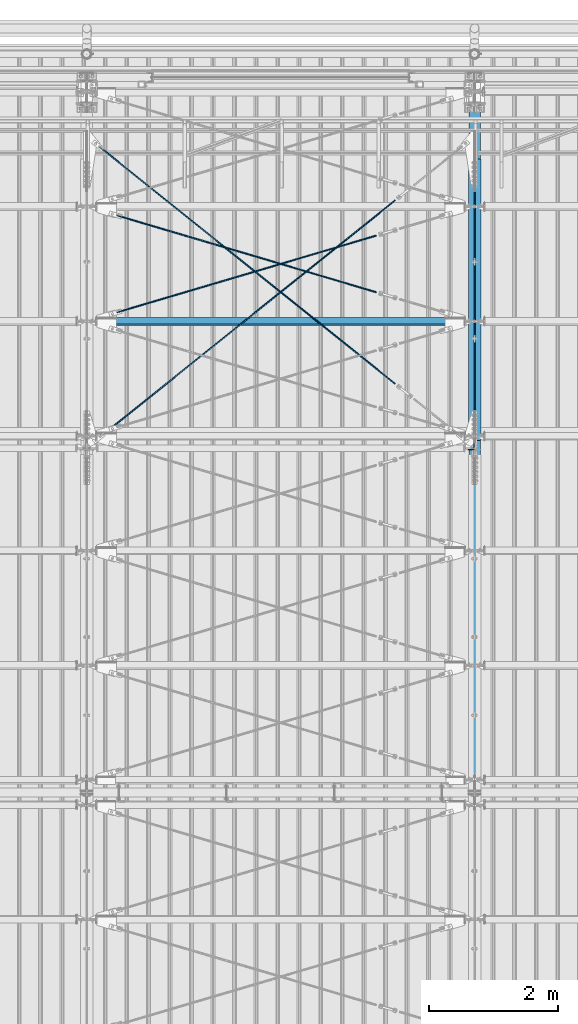
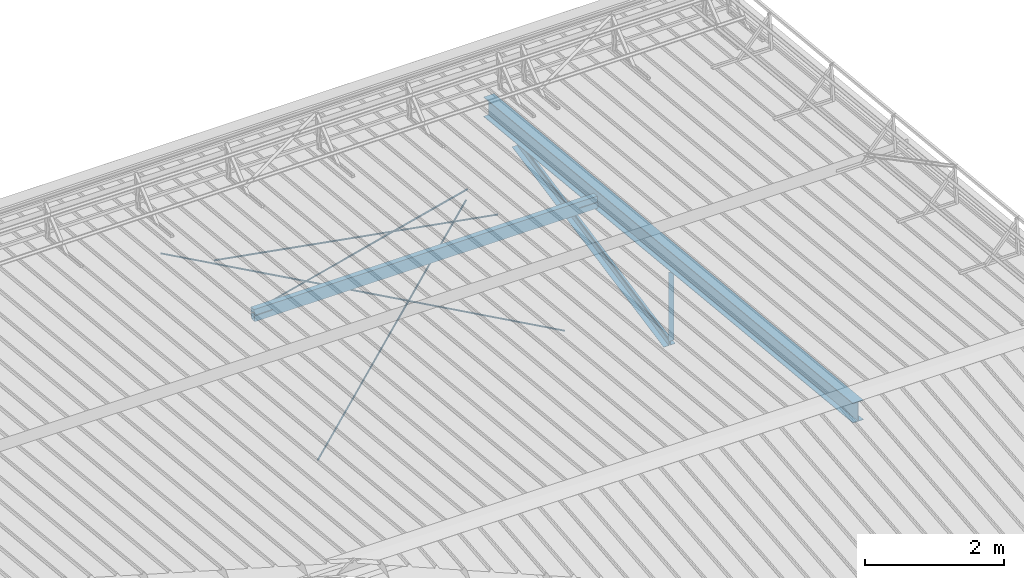
# One storey, part 287 of 709: 9 beams, 6 openings, 9 elements without a shape of their own.
"""IFC4 building model written with IfcOpenShell, lengths in millimetres."""

from ifc_helpers import new_model, si_unit, direction, frame, origin_with_axes, place, context, subcontext, project, spatial, line, indexed_curve, outline, extrude, polygons, material, element, aggregate, save


model = new_model("IFC4")

# Units and contexts
model_context = context("Model", 3, precision=0.2, world=origin_with_axes(), true_north=direction((0.0, 1.0)))
body_context = subcontext(model_context, "Body", "Model", "MODEL_VIEW")
reference_context = subcontext(model_context, "Reference", "Model", "MODEL_VIEW")
ifc_project = project(units=[si_unit("LENGTHUNIT", "METRE", prefix="MILLI"), si_unit("AREAUNIT", "SQUARE_METRE"), si_unit("VOLUMEUNIT", "CUBIC_METRE"), si_unit("MASSUNIT", "GRAM", prefix="KILO"), si_unit("TIMEUNIT", "SECOND"), si_unit("PLANEANGLEUNIT", "RADIAN"), si_unit("SOLIDANGLEUNIT", "STERADIAN"), si_unit("THERMODYNAMICTEMPERATUREUNIT", "DEGREE_CELSIUS"), si_unit("LUMINOUSINTENSITYUNIT", "LUMEN")], contexts=[model_context])

# Site, building, storey
site_placement = place(None, origin_with_axes())
site = spatial("IfcSite", under=ifc_project, at=site_placement, CompositionType="ELEMENT")
building_placement = place(site_placement, origin_with_axes())
building = spatial("IfcBuilding", under=site, at=building_placement, Name="Undefined", CompositionType="ELEMENT")
storey_placement = place(building_placement, origin_with_axes())
storey = spatial("IfcBuildingStorey", under=building, at=storey_placement, Name="Undefined", CompositionType="ELEMENT", Elevation=0.0)

# Assembly, beam
assembly_1_placement = place(storey_placement, frame((46000.0, 21654.0, 7089.70002), z_axis=(-1.0, 0.0, 0.0), x_axis=(0.0, -0.9950371902, 0.099503719)))
assembly_1 = element("IfcElementAssembly", 1, at=assembly_1_placement, inside=storey)
ifc_material_1 = material(Name="C355-5", Category="STEEL")
beam_1_placement = place(assembly_1_placement, origin_with_axes())
beam_1 = element("IfcBeam", 2, at=beam_1_placement, material=ifc_material_1, ObjectType="432", context=body_context, shape_type="Tessellation", body=[
    polygons([(3.80474, -173.0, -87.0), (4.70474, -164.0, -87.0), (10665.6128, -164.0, -87.0), (10664.7128, -173.0, -87.0), (4.70474, -164.0, -3.0), (10665.6128, -164.0, -3.0), (37.50474, 164.0, -3.0), (10698.4128, 164.0, -3.0), (37.50474, 164.0, -87.0), (10698.4128, 164.0, -87.0), (38.40474, 173.0, -87.0), (10699.3128, 173.0, -87.0), (38.40474, 173.0, 87.0), (10699.3128, 173.0, 87.0), (37.50474, 164.0, 87.0), (10698.4128, 164.0, 87.0), (37.50474, 164.0, 3.0), (10698.4128, 164.0, 3.0), (4.70474, -164.0, 3.0), (10665.6128, -164.0, 3.0), (4.70474, -164.0, 87.0), (10665.6128, -164.0, 87.0), (3.80474, -173.0, 87.0), (10664.7128, -173.0, 87.0)], [[[1, 2, 3, 4]], [[2, 5, 6, 3]], [[5, 7, 8, 6]], [[7, 9, 10, 8]], [[9, 11, 12, 10]], [[11, 13, 14, 12]], [[13, 15, 16, 14]], [[15, 17, 18, 16]], [[17, 19, 20, 18]], [[19, 21, 22, 20]], [[21, 23, 24, 22]], [[23, 1, 4, 24]], [[6, 8, 10, 12, 14, 16, 18, 20, 22, 24, 4, 3]], [[23, 21, 19, 17, 15, 13, 11, 9, 7, 5, 2, 1]]], closed=True),
])
aggregate(assembly_1, [beam_1])

assembly_2_placement = place(storey_placement, frame((46051.0, 21649.9404, 7109.99804), z_axis=(0.0, -0.1961161349, 0.9805806757), x_axis=(0.0, -0.9805806757, -0.1961161349)))
assembly_2 = element("IfcElementAssembly", 3, at=assembly_2_placement, inside=storey)
ifc_material_2 = material(Name="C345-5", Category="STEEL")
beam_2_placement = place(assembly_2_placement, origin_with_axes())
beam_2 = element("IfcBeam", 4, at=beam_2_placement, material=ifc_material_2, ObjectType="435", context=body_context, shape_type="Tessellation", body=[
    polygons([(873.96605, -45.0, -45.0), (873.96605, 45.0, -45.0), (5317.375, 45.0, -45.0), (5317.375, -45.0, -45.0), (873.96605, 45.0, -39.0), (5317.375, 45.0, -39.0), (873.96605, -39.0, -39.0), (5317.375, -39.0, -39.0), (873.96605, -39.0, 45.0), (5317.375, -39.0, 45.0), (873.96605, -45.0, 45.0), (5317.375, -45.0, 45.0)], [[[1, 2, 3, 4]], [[2, 5, 6, 3]], [[5, 7, 8, 6]], [[7, 9, 10, 8]], [[9, 11, 12, 10]], [[11, 1, 4, 12]], [[6, 8, 10, 12, 4, 3]], [[11, 9, 7, 5, 2, 1]]], closed=True),
])
aggregate(assembly_2, [beam_2])

assembly_3_placement = place(storey_placement, frame((45949.0, 16322.9404, 6044.59804), z_axis=(0.0, -0.1961161349, 0.9805806757), x_axis=(0.0, 0.9805806757, 0.1961161349)))
assembly_3 = element("IfcElementAssembly", 5, at=assembly_3_placement, inside=storey)
beam_3_placement = place(assembly_3_placement, origin_with_axes())
beam_3 = element("IfcBeam", 6, at=beam_3_placement, material=ifc_material_2, ObjectType="435", context=body_context, shape_type="Tessellation", body=[
    polygons([(115.12039, -45.0, -45.0), (115.12039, 45.0, -45.0), (4558.52934, 45.0, -45.0), (4558.52934, -45.0, -45.0), (115.12039, 45.0, -39.0), (4558.52934, 45.0, -39.0), (115.12039, -39.0, -39.0), (4558.52934, -39.0, -39.0), (115.12039, -39.0, 45.0), (4558.52934, -39.0, 45.0), (115.12039, -45.0, 45.0), (4558.52934, -45.0, 45.0)], [[[1, 2, 3, 4]], [[2, 5, 6, 3]], [[5, 7, 8, 6]], [[7, 9, 10, 8]], [[9, 11, 12, 10]], [[11, 1, 4, 12]], [[6, 8, 10, 12, 4, 3]], [[11, 9, 7, 5, 2, 1]]], closed=True),
])
aggregate(assembly_3, [beam_3])

assembly_4_placement = place(storey_placement, frame((45949.0, 16347.7, 7622.40002), z_axis=(0.0, 1.0, 0.0), x_axis=(0.0, 0.0, -1.0)))
assembly_4 = element("IfcElementAssembly", 7, at=assembly_4_placement, inside=storey)
beam_4_placement = place(assembly_4_placement, origin_with_axes())
beam_4 = element("IfcBeam", 8, at=beam_4_placement, material=ifc_material_2, ObjectType="436", context=body_context, shape_type="Tessellation", body=[
    polygons([(198.6891, -45.0, -45.0), (198.6891, 45.0, -45.0), (1412.4, 45.0, -45.0), (1412.4, -45.0, -45.0), (198.6891, 45.0, -39.0), (1412.4, 45.0, -39.0), (198.6891, -39.0, -39.0), (1412.4, -39.0, -39.0), (198.6891, -39.0, 45.0), (1412.4, -39.0, 45.0), (198.6891, -45.0, 45.0), (1412.4, -45.0, 45.0)], [[[1, 2, 3, 4]], [[2, 5, 6, 3]], [[5, 7, 8, 6]], [[7, 9, 10, 8]], [[9, 11, 12, 10]], [[11, 1, 4, 12]], [[6, 8, 10, 12, 4, 3]], [[11, 9, 7, 5, 2, 1]]], closed=True),
])
aggregate(assembly_4, [beam_4])

# Assembly, beam, voiding feature
assembly_5_placement = place(storey_placement, frame((40000.0, 16334.90348, 5984.78262), z_axis=(0.625451877, -0.7802627439, 1e-10), x_axis=(0.7742288439, 0.6206151549, 0.124123031)))
assembly_5 = element("IfcElementAssembly", 9, at=assembly_5_placement, inside=storey)
beam_5_placement = place(assembly_5_placement, origin_with_axes())
beam_5 = element("IfcBeam", 10, at=beam_5_placement, material=ifc_material_1, ObjectType="480", context=body_context, shape_type="Tessellation", body=[
    polygons([(6339.64669, 7.36121, 4.25), (6339.64669, 6.01041, 6.0104), (6339.64669, 4.25, 7.36121), (6339.64669, 2.19996, 8.21037), (6339.64669, 0.0, 8.5), (6339.64669, -2.19996, 8.21037), (6339.64669, -4.25, 7.36121), (6339.64669, -6.01041, 6.0104), (6339.64669, -7.36122, 4.25), (6339.64669, -8.21037, 2.19996), (6339.64669, -8.5, 0.0), (6339.64669, -8.21037, -2.19996), (6339.64669, -7.36122, -4.25), (6339.64669, -6.01041, -6.01041), (6339.64669, -4.25, -7.36122), (6339.64669, -2.19996, -8.21037), (6339.64669, 0.0, -8.5), (6339.64669, 2.19996, -8.21037), (6339.64669, 4.25, -7.36122), (6339.64669, 6.01041, -6.01041), (6339.64669, 7.36121, -4.25), (6339.64669, 8.21037, -2.19996), (6339.64669, 8.5, 0.0), (6339.64669, 8.21037, 2.19996), (6159.64669, 8.21037, 2.19996), (6159.64669, 7.36121, 4.25), (6159.64669, 6.01041, 6.0104), (6159.64669, 4.25, 7.36121), (6159.64669, 2.19996, 8.21037), (6159.64669, 0.0, 8.5), (6159.64669, -2.19996, 8.21037), (6159.64669, -4.25, 7.36121), (6159.64669, -6.01041, 6.0104), (6159.64669, -7.36122, 4.25), (6159.64669, -8.21037, 2.19996), (6159.64669, -8.5, 0.0), (6159.64669, -8.21037, -2.19996), (6159.64669, -7.36122, -4.25), (6159.64669, -6.01041, -6.01041), (6159.64669, -4.25, -7.36122), (6159.64669, -2.19996, -8.21037), (6159.64669, 0.0, -8.5), (6159.64669, 2.19996, -8.21037), (6159.64669, 4.25, -7.36122), (6159.64669, 6.01041, -6.01041), (6159.64669, 7.36121, -4.25), (6159.64669, 8.21037, -2.19996), (6159.64669, 8.5, 0.0), (6159.64669, 10.0, 0.0), (6159.64669, 9.65926, 2.58819), (6159.64669, 8.66025, 5.0), (6159.64669, 7.07107, 7.07107), (6159.64669, 5.0, 8.66025), (6159.64669, 2.58819, 9.65926), (6159.64669, 0.0, 10.0), (6159.64669, -2.58819, 9.65926), (6159.64669, -5.0, 8.66025), (6159.64669, -7.07107, 7.07107), (6159.64669, -8.66025, 5.0), (6159.64669, -9.65926, 2.58819), (6159.64669, -10.0, 0.0), (6159.64669, -9.65926, -2.58819), (6159.64669, -8.66025, -5.0), (6159.64669, -7.07107, -7.07107), (6159.64669, -5.0, -8.66025), (6159.64669, -2.58819, -9.65926), (6159.64669, 0.0, -10.0), (6159.64669, 2.58819, -9.65926), (6159.64669, 5.0, -8.66025), (6159.64669, 7.07107, -7.07107), (6159.64669, 8.66025, -5.0), (6159.64669, 9.65926, -2.58819), (259.57474, 2.58819, 9.65926), (259.57474, 5.0, 8.66025), (259.57474, 7.07107, 7.07107), (259.57474, 8.66025, 5.0), (259.57474, 9.65926, 2.58819), (259.57474, 10.0, 0.0), (259.57474, 9.65926, -2.58819), (259.57474, 8.66025, -5.0), (259.57474, 7.07107, -7.07107), (259.57474, 5.0, -8.66025), (259.57474, 2.58819, -9.65926), (259.57474, 0.0, -10.0), (259.57474, -2.58819, -9.65926), (259.57474, -5.0, -8.66025), (259.57474, -7.07107, -7.07107), (259.57474, -8.66025, -5.0), (259.57474, -9.65926, -2.58819), (259.57474, -10.0, 0.0), (259.57474, -9.65926, 2.58819), (259.57474, -8.66025, 5.0), (259.57474, -7.07107, 7.07107), (259.57474, -5.0, 8.66025), (259.57474, -2.58819, 9.65926), (259.57474, 0.0, 10.0)], [[[1, 2, 3, 4, 5, 6, 7, 8, 9, 10, 11, 12, 13, 14, 15, 16, 17, 18, 19, 20, 21, 22, 23, 24]], [[24, 25, 26, 1]], [[1, 26, 27, 2]], [[2, 27, 28, 3]], [[3, 28, 29, 4]], [[4, 29, 30, 5]], [[5, 30, 31, 6]], [[6, 31, 32, 7]], [[7, 32, 33, 8]], [[8, 33, 34, 9]], [[9, 34, 35, 10]], [[10, 35, 36, 11]], [[11, 36, 37, 12]], [[12, 37, 38, 13]], [[13, 38, 39, 14]], [[14, 39, 40, 15]], [[15, 40, 41, 16]], [[16, 41, 42, 17]], [[17, 42, 43, 18]], [[18, 43, 44, 19]], [[19, 44, 45, 20]], [[20, 45, 46, 21]], [[21, 46, 47, 22]], [[22, 47, 48, 23]], [[23, 48, 25, 24]], [[49, 50, 51, 52, 53, 54, 55, 56, 57, 58, 59, 60, 61, 62, 63, 64, 65, 66, 67, 68, 69, 70, 71, 72], [47, 46, 45, 44, 43, 42, 41, 40, 39, 38, 37, 36, 35, 34, 33, 32, 31, 30, 29, 28, 27, 26, 25, 48]], [[73, 74, 75, 76, 77, 78, 79, 80, 81, 82, 83, 84, 85, 86, 87, 88, 89, 90, 91, 92, 93, 94, 95, 96]], [[79, 78, 49, 72]], [[80, 79, 72, 71]], [[81, 80, 71, 70]], [[82, 81, 70, 69]], [[83, 82, 69, 68]], [[84, 83, 68, 67]], [[85, 84, 67, 66]], [[86, 85, 66, 65]], [[87, 86, 65, 64]], [[88, 87, 64, 63]], [[89, 88, 63, 62]], [[90, 89, 62, 61]], [[91, 90, 61, 60]], [[92, 91, 60, 59]], [[93, 92, 59, 58]], [[94, 93, 58, 57]], [[95, 94, 57, 56]], [[96, 95, 56, 55]], [[73, 96, 55, 54]], [[74, 73, 54, 53]], [[75, 74, 53, 52]], [[76, 75, 52, 51]], [[77, 76, 51, 50]], [[78, 77, 50, 49]]], closed=True),
])
voiding_feature_1_placement = place(beam_5_placement, frame((6339.64669, 0.0, 0.0), z_axis=(0.0, 1.0, 0.0), x_axis=(-1.0, 0.0, 0.0)))
element("IfcVoidingFeature", 11, at=voiding_feature_1_placement, cuts=beam_5, PredefinedType="HOLE", context=reference_context, identifier="Reference", shape_type="SolidModel", body=[
    extrude(outline(indexed_curve([(10.5, 0.0), (10.14222, 2.7176), (9.09327, 5.25), (7.42462, 7.42462), (5.25, 9.09327), (2.7176, 10.14222), (0.0, 10.5), (-2.7176, 10.14222), (-5.25, 9.09327), (-7.42462, 7.42462), (-9.09327, 5.25), (-10.14222, 2.7176), (-10.5, 0.0), (-10.14222, -2.7176), (-9.09327, -5.25), (-7.42462, -7.42462), (-5.25, -9.09327), (-2.7176, -10.14222), (0.0, -10.5), (2.7176, -10.14222), (5.25, -9.09327), (7.42462, -7.42462), (9.09327, -5.25), (10.14222, -2.7176)], segments=[line(1, 2, 3, 4, 5, 6, 7, 8, 9, 10, 11, 12, 13, 14, 15, 16, 17, 18, 19, 20, 21, 22, 23, 24, 1)])), frame((0.0, 0.0, 0.0), z_axis=(-1.0, 0.0, 0.0), x_axis=(0.0, 0.0, 1.0)), (0.0, 0.0, -1.0), 180.0),
])
aggregate(assembly_5, [beam_5])

assembly_6_placement = place(storey_placement, frame((40000.0, 21144.45166, 6946.69226), z_axis=(-0.625451877, -0.7802627439, 1e-10), x_axis=(0.7742288439, -0.6206151549, -0.124123031)))
assembly_6 = element("IfcElementAssembly", 12, at=assembly_6_placement, inside=storey)
beam_6_placement = place(assembly_6_placement, origin_with_axes())
beam_6 = element("IfcBeam", 13, at=beam_6_placement, material=ifc_material_1, ObjectType="485", context=body_context, shape_type="Tessellation", body=[
    polygons([(6339.64669, 7.36122, 4.25), (6339.64669, 6.01041, 6.01041), (6339.64669, 4.25, 7.36122), (6339.64669, 2.19996, 8.21037), (6339.64669, 0.0, 8.5), (6339.64669, -2.19996, 8.21037), (6339.64669, -4.25, 7.36122), (6339.64669, -6.01041, 6.01041), (6339.64669, -7.36121, 4.25), (6339.64669, -8.21037, 2.19996), (6339.64669, -8.5, 0.0), (6339.64669, -8.21037, -2.19996), (6339.64669, -7.36121, -4.25), (6339.64669, -6.01041, -6.0104), (6339.64669, -4.25, -7.36121), (6339.64669, -2.19996, -8.21037), (6339.64669, 0.0, -8.5), (6339.64669, 2.19996, -8.21037), (6339.64669, 4.25, -7.36121), (6339.64669, 6.01041, -6.0104), (6339.64669, 7.36122, -4.25), (6339.64669, 8.21037, -2.19996), (6339.64669, 8.5, 0.0), (6339.64669, 8.21037, 2.19996), (6159.64669, 8.21037, 2.19996), (6159.64669, 7.36122, 4.25), (6159.64669, 6.01041, 6.01041), (6159.64669, 4.25, 7.36122), (6159.64669, 2.19996, 8.21037), (6159.64669, 0.0, 8.5), (6159.64669, -2.19996, 8.21037), (6159.64669, -4.25, 7.36122), (6159.64669, -6.01041, 6.01041), (6159.64669, -7.36121, 4.25), (6159.64669, -8.21037, 2.19996), (6159.64669, -8.5, 0.0), (6159.64669, -8.21037, -2.19996), (6159.64669, -7.36121, -4.25), (6159.64669, -6.01041, -6.0104), (6159.64669, -4.25, -7.36121), (6159.64669, -2.19996, -8.21037), (6159.64669, 0.0, -8.5), (6159.64669, 2.19996, -8.21037), (6159.64669, 4.25, -7.36121), (6159.64669, 6.01041, -6.0104), (6159.64669, 7.36122, -4.25), (6159.64669, 8.21037, -2.19996), (6159.64669, 8.5, 0.0), (6159.64669, 10.0, 0.0), (6159.64669, 9.65926, 2.58819), (6159.64669, 8.66025, 5.0), (6159.64669, 7.07107, 7.07107), (6159.64669, 5.0, 8.66025), (6159.64669, 2.58819, 9.65926), (6159.64669, 0.0, 10.0), (6159.64669, -2.58819, 9.65926), (6159.64669, -5.0, 8.66025), (6159.64669, -7.07107, 7.07107), (6159.64669, -8.66025, 5.0), (6159.64669, -9.65926, 2.58819), (6159.64669, -10.0, 0.0), (6159.64669, -9.65926, -2.58819), (6159.64669, -8.66025, -5.0), (6159.64669, -7.07107, -7.07107), (6159.64669, -5.0, -8.66025), (6159.64669, -2.58819, -9.65926), (6159.64669, 0.0, -10.0), (6159.64669, 2.58819, -9.65926), (6159.64669, 5.0, -8.66025), (6159.64669, 7.07107, -7.07107), (6159.64669, 8.66025, -5.0), (6159.64669, 9.65926, -2.58819), (246.65866, 2.58819, 9.65926), (246.65866, 5.0, 8.66025), (246.65866, 7.07107, 7.07107), (246.65866, 8.66025, 5.0), (246.65866, 9.65926, 2.58819), (246.65866, 10.0, 0.0), (246.65866, 9.65926, -2.58819), (246.65866, 8.66025, -5.0), (246.65866, 7.07107, -7.07107), (246.65866, 5.0, -8.66025), (246.65866, 2.58819, -9.65926), (246.65866, 0.0, -10.0), (246.65866, -2.58819, -9.65926), (246.65866, -5.0, -8.66025), (246.65866, -7.07107, -7.07107), (246.65866, -8.66025, -5.0), (246.65866, -9.65926, -2.58819), (246.65866, -10.0, 0.0), (246.65866, -9.65926, 2.58819), (246.65866, -8.66025, 5.0), (246.65866, -7.07107, 7.07107), (246.65866, -5.0, 8.66025), (246.65866, -2.58819, 9.65926), (246.65866, 0.0, 10.0)], [[[1, 2, 3, 4, 5, 6, 7, 8, 9, 10, 11, 12, 13, 14, 15, 16, 17, 18, 19, 20, 21, 22, 23, 24]], [[24, 25, 26, 1]], [[1, 26, 27, 2]], [[2, 27, 28, 3]], [[3, 28, 29, 4]], [[4, 29, 30, 5]], [[5, 30, 31, 6]], [[6, 31, 32, 7]], [[7, 32, 33, 8]], [[8, 33, 34, 9]], [[9, 34, 35, 10]], [[10, 35, 36, 11]], [[11, 36, 37, 12]], [[12, 37, 38, 13]], [[13, 38, 39, 14]], [[14, 39, 40, 15]], [[15, 40, 41, 16]], [[16, 41, 42, 17]], [[17, 42, 43, 18]], [[18, 43, 44, 19]], [[19, 44, 45, 20]], [[20, 45, 46, 21]], [[21, 46, 47, 22]], [[22, 47, 48, 23]], [[23, 48, 25, 24]], [[49, 50, 51, 52, 53, 54, 55, 56, 57, 58, 59, 60, 61, 62, 63, 64, 65, 66, 67, 68, 69, 70, 71, 72], [47, 46, 45, 44, 43, 42, 41, 40, 39, 38, 37, 36, 35, 34, 33, 32, 31, 30, 29, 28, 27, 26, 25, 48]], [[73, 74, 75, 76, 77, 78, 79, 80, 81, 82, 83, 84, 85, 86, 87, 88, 89, 90, 91, 92, 93, 94, 95, 96]], [[79, 78, 49, 72]], [[80, 79, 72, 71]], [[81, 80, 71, 70]], [[82, 81, 70, 69]], [[83, 82, 69, 68]], [[84, 83, 68, 67]], [[85, 84, 67, 66]], [[86, 85, 66, 65]], [[87, 86, 65, 64]], [[88, 87, 64, 63]], [[89, 88, 63, 62]], [[90, 89, 62, 61]], [[91, 90, 61, 60]], [[92, 91, 60, 59]], [[93, 92, 59, 58]], [[94, 93, 58, 57]], [[95, 94, 57, 56]], [[96, 95, 56, 55]], [[73, 96, 55, 54]], [[74, 73, 54, 53]], [[75, 74, 53, 52]], [[76, 75, 52, 51]], [[77, 76, 51, 50]], [[78, 77, 50, 49]]], closed=True),
])
voiding_feature_2_placement = place(beam_6_placement, frame((6339.64669, 0.0, 0.0), z_axis=(0.0, 1.0, 0.0), x_axis=(-1.0, 0.0, 0.0)))
element("IfcVoidingFeature", 14, at=voiding_feature_2_placement, cuts=beam_6, PredefinedType="HOLE", context=reference_context, identifier="Reference", shape_type="SolidModel", body=[
    extrude(outline(indexed_curve([(10.5, 0.0), (10.14222, 2.7176), (9.09327, 5.25), (7.42462, 7.42462), (5.25, 9.09327), (2.7176, 10.14222), (0.0, 10.5), (-2.7176, 10.14222), (-5.25, 9.09327), (-7.42462, 7.42462), (-9.09327, 5.25), (-10.14222, 2.7176), (-10.5, 0.0), (-10.14222, -2.7176), (-9.09327, -5.25), (-7.42462, -7.42462), (-5.25, -9.09327), (-2.7176, -10.14222), (0.0, -10.5), (2.7176, -10.14222), (5.25, -9.09327), (7.42462, -7.42462), (9.09327, -5.25), (10.14222, -2.7176)], segments=[line(1, 2, 3, 4, 5, 6, 7, 8, 9, 10, 11, 12, 13, 14, 15, 16, 17, 18, 19, 20, 21, 22, 23, 24, 1)])), frame((0.0, 0.0, 0.0), z_axis=(-1.0, 0.0, 0.0), x_axis=(0.0, 0.0, 1.0)), (0.0, 0.0, -1.0), 180.0),
])
aggregate(assembly_6, [beam_6])

assembly_7_placement = place(storey_placement, frame((40000.0, 18287.44615, 7507.7594), z_axis=(0.2852311229, -0.9537021177, 0.0953702118), x_axis=(0.9584587662, 0.2838155751, -0.028381558)))
assembly_7 = element("IfcElementAssembly", 15, at=assembly_7_placement, inside=storey)
beam_7_placement = place(assembly_7_placement, origin_with_axes())
beam_7 = element("IfcBeam", 16, at=beam_7_placement, material=ifc_material_1, ObjectType="570", context=body_context, shape_type="Tessellation", body=[
    polygons([(4850.05021, 7.36122, 4.25), (4850.05021, 6.01041, 6.01041), (4850.05021, 4.25, 7.36121), (4850.05021, 2.19996, 8.21037), (4850.05021, 0.0, 8.5), (4850.05021, -2.19996, 8.21037), (4850.05021, -4.25, 7.36121), (4850.05021, -6.01041, 6.01041), (4850.05021, -7.36121, 4.25), (4850.05021, -8.21037, 2.19996), (4850.05021, -8.5, 0.0), (4850.05021, -8.21037, -2.19996), (4850.05021, -7.36121, -4.25), (4850.05021, -6.01041, -6.01041), (4850.05021, -4.25, -7.36122), (4850.05021, -2.19996, -8.21037), (4850.05021, 0.0, -8.5), (4850.05021, 2.19996, -8.21037), (4850.05021, 4.25, -7.36122), (4850.05021, 6.01041, -6.01041), (4850.05021, 7.36122, -4.25), (4850.05021, 8.21037, -2.19996), (4850.05021, 8.5, 0.0), (4850.05021, 8.21037, 2.19996), (4670.05021, 8.21037, 2.19996), (4670.05021, 7.36122, 4.25), (4670.05021, 6.01041, 6.01041), (4670.05021, 4.25, 7.36121), (4670.05021, 2.19996, 8.21037), (4670.05021, 0.0, 8.5), (4670.05021, -2.19996, 8.21037), (4670.05021, -4.25, 7.36121), (4670.05021, -6.01041, 6.01041), (4670.05021, -7.36121, 4.25), (4670.05021, -8.21037, 2.19996), (4670.05021, -8.5, 0.0), (4670.05021, -8.21037, -2.19996), (4670.05021, -7.36121, -4.25), (4670.05021, -6.01041, -6.01041), (4670.05021, -4.25, -7.36122), (4670.05021, -2.19996, -8.21037), (4670.05021, 0.0, -8.5), (4670.05021, 2.19996, -8.21037), (4670.05021, 4.25, -7.36122), (4670.05021, 6.01041, -6.01041), (4670.05021, 7.36122, -4.25), (4670.05021, 8.21037, -2.19996), (4670.05021, 8.5, 0.0), (4670.05021, 10.0, 0.0), (4670.05021, 9.65926, 2.58819), (4670.05021, 8.66025, 5.0), (4670.05021, 7.07107, 7.07107), (4670.05021, 5.0, 8.66025), (4670.05021, 2.58819, 9.65926), (4670.05021, 0.0, 10.0), (4670.05021, -2.58819, 9.65926), (4670.05021, -5.0, 8.66025), (4670.05021, -7.07107, 7.07107), (4670.05021, -8.66025, 5.0), (4670.05021, -9.65926, 2.58819), (4670.05021, -10.0, 0.0), (4670.05021, -9.65926, -2.58819), (4670.05021, -8.66025, -5.0), (4670.05021, -7.07107, -7.07107), (4670.05021, -5.0, -8.66025), (4670.05021, -2.58819, -9.65926), (4670.05021, 0.0, -10.0), (4670.05021, 2.58819, -9.65926), (4670.05021, 5.0, -8.66025), (4670.05021, 7.07107, -7.07107), (4670.05021, 8.66025, -5.0), (4670.05021, 9.65926, -2.58819), (483.0251, 2.58819, 9.65926), (483.0251, 5.0, 8.66025), (483.0251, 7.07107, 7.07107), (483.0251, 8.66025, 5.0), (483.0251, 9.65926, 2.58819), (483.0251, 10.0, 0.0), (483.0251, 9.65926, -2.58819), (483.0251, 8.66025, -5.0), (483.0251, 7.07107, -7.07107), (483.0251, 5.0, -8.66025), (483.0251, 2.58819, -9.65926), (483.0251, 0.0, -10.0), (483.0251, -2.58819, -9.65926), (483.0251, -5.0, -8.66025), (483.0251, -7.07107, -7.07107), (483.0251, -8.66025, -5.0), (483.0251, -9.65926, -2.58819), (483.0251, -10.0, 0.0), (483.0251, -9.65926, 2.58819), (483.0251, -8.66025, 5.0), (483.0251, -7.07107, 7.07107), (483.0251, -5.0, 8.66025), (483.0251, -2.58819, 9.65926), (483.0251, 0.0, 10.0)], [[[1, 2, 3, 4, 5, 6, 7, 8, 9, 10, 11, 12, 13, 14, 15, 16, 17, 18, 19, 20, 21, 22, 23, 24]], [[24, 25, 26, 1]], [[1, 26, 27, 2]], [[2, 27, 28, 3]], [[3, 28, 29, 4]], [[4, 29, 30, 5]], [[5, 30, 31, 6]], [[6, 31, 32, 7]], [[7, 32, 33, 8]], [[8, 33, 34, 9]], [[9, 34, 35, 10]], [[10, 35, 36, 11]], [[11, 36, 37, 12]], [[12, 37, 38, 13]], [[13, 38, 39, 14]], [[14, 39, 40, 15]], [[15, 40, 41, 16]], [[16, 41, 42, 17]], [[17, 42, 43, 18]], [[18, 43, 44, 19]], [[19, 44, 45, 20]], [[20, 45, 46, 21]], [[21, 46, 47, 22]], [[22, 47, 48, 23]], [[23, 48, 25, 24]], [[49, 50, 51, 52, 53, 54, 55, 56, 57, 58, 59, 60, 61, 62, 63, 64, 65, 66, 67, 68, 69, 70, 71, 72], [47, 46, 45, 44, 43, 42, 41, 40, 39, 38, 37, 36, 35, 34, 33, 32, 31, 30, 29, 28, 27, 26, 25, 48]], [[73, 74, 75, 76, 77, 78, 79, 80, 81, 82, 83, 84, 85, 86, 87, 88, 89, 90, 91, 92, 93, 94, 95, 96]], [[79, 78, 49, 72]], [[80, 79, 72, 71]], [[81, 80, 71, 70]], [[82, 81, 70, 69]], [[83, 82, 69, 68]], [[84, 83, 68, 67]], [[85, 84, 67, 66]], [[86, 85, 66, 65]], [[87, 86, 65, 64]], [[88, 87, 64, 63]], [[89, 88, 63, 62]], [[90, 89, 62, 61]], [[91, 90, 61, 60]], [[92, 91, 60, 59]], [[93, 92, 59, 58]], [[94, 93, 58, 57]], [[95, 94, 57, 56]], [[96, 95, 56, 55]], [[73, 96, 55, 54]], [[74, 73, 54, 53]], [[75, 74, 53, 52]], [[76, 75, 52, 51]], [[77, 76, 51, 50]], [[78, 77, 50, 49]]], closed=True),
])
voiding_feature_3_placement = place(beam_7_placement, frame((4850.05021, 0.0, 0.0), z_axis=(0.0, 1.0, 0.0), x_axis=(-1.0, 0.0, 0.0)))
element("IfcVoidingFeature", 17, at=voiding_feature_3_placement, cuts=beam_7, PredefinedType="HOLE", context=reference_context, identifier="Reference", shape_type="SolidModel", body=[
    extrude(outline(indexed_curve([(10.5, 0.0), (10.14222, 2.7176), (9.09327, 5.25), (7.42462, 7.42462), (5.25, 9.09327), (2.7176, 10.14222), (0.0, 10.5), (-2.7176, 10.14222), (-5.25, 9.09327), (-7.42462, 7.42462), (-9.09327, 5.25), (-10.14222, 2.7176), (-10.5, 0.0), (-10.14222, -2.7176), (-9.09327, -5.25), (-7.42462, -7.42462), (-5.25, -9.09327), (-2.7176, -10.14222), (0.0, -10.5), (2.7176, -10.14222), (5.25, -9.09327), (7.42462, -7.42462), (9.09327, -5.25), (10.14222, -2.7176)], segments=[line(1, 2, 3, 4, 5, 6, 7, 8, 9, 10, 11, 12, 13, 14, 15, 16, 17, 18, 19, 20, 21, 22, 23, 24, 1)])), frame((0.0, 0.0, 0.0), z_axis=(-1.0, 0.0, 0.0), x_axis=(0.0, 0.0, 1.0)), (0.0, 0.0, -1.0), 180.0),
])
aggregate(assembly_7, [beam_7])

assembly_8_placement = place(storey_placement, frame((40000.0, 20064.14591, 7330.08943), z_axis=(-0.2852311229, -0.9537021177, 0.0953702118), x_axis=(0.9584587662, -0.2838155751, 0.028381558)))
assembly_8 = element("IfcElementAssembly", 18, at=assembly_8_placement, inside=storey)
beam_8_placement = place(assembly_8_placement, origin_with_axes())
beam_8 = element("IfcBeam", 19, at=beam_8_placement, material=ifc_material_1, ObjectType="570", context=body_context, shape_type="Tessellation", body=[
    polygons([(4850.05021, 7.36122, 4.25), (4850.05021, 6.01041, 6.01041), (4850.05021, 4.25, 7.36121), (4850.05021, 2.19996, 8.21037), (4850.05021, 0.0, 8.5), (4850.05021, -2.19996, 8.21037), (4850.05021, -4.25, 7.36121), (4850.05021, -6.01041, 6.01041), (4850.05021, -7.36121, 4.25), (4850.05021, -8.21037, 2.19996), (4850.05021, -8.5, 0.0), (4850.05021, -8.21037, -2.19996), (4850.05021, -7.36121, -4.25), (4850.05021, -6.01041, -6.01041), (4850.05021, -4.25, -7.36122), (4850.05021, -2.19996, -8.21037), (4850.05021, 0.0, -8.5), (4850.05021, 2.19996, -8.21037), (4850.05021, 4.25, -7.36122), (4850.05021, 6.01041, -6.01041), (4850.05021, 7.36122, -4.25), (4850.05021, 8.21037, -2.19996), (4850.05021, 8.5, 0.0), (4850.05021, 8.21037, 2.19996), (4670.05021, 8.21037, 2.19996), (4670.05021, 7.36122, 4.25), (4670.05021, 6.01041, 6.01041), (4670.05021, 4.25, 7.36121), (4670.05021, 2.19996, 8.21037), (4670.05021, 0.0, 8.5), (4670.05021, -2.19996, 8.21037), (4670.05021, -4.25, 7.36121), (4670.05021, -6.01041, 6.01041), (4670.05021, -7.36121, 4.25), (4670.05021, -8.21037, 2.19996), (4670.05021, -8.5, 0.0), (4670.05021, -8.21037, -2.19996), (4670.05021, -7.36121, -4.25), (4670.05021, -6.01041, -6.01041), (4670.05021, -4.25, -7.36122), (4670.05021, -2.19996, -8.21037), (4670.05021, 0.0, -8.5), (4670.05021, 2.19996, -8.21037), (4670.05021, 4.25, -7.36122), (4670.05021, 6.01041, -6.01041), (4670.05021, 7.36122, -4.25), (4670.05021, 8.21037, -2.19996), (4670.05021, 8.5, 0.0), (4670.05021, 10.0, 0.0), (4670.05021, 9.65926, 2.58819), (4670.05021, 8.66025, 5.0), (4670.05021, 7.07107, 7.07107), (4670.05021, 5.0, 8.66025), (4670.05021, 2.58819, 9.65926), (4670.05021, 0.0, 10.0), (4670.05021, -2.58819, 9.65926), (4670.05021, -5.0, 8.66025), (4670.05021, -7.07107, 7.07107), (4670.05021, -8.66025, 5.0), (4670.05021, -9.65926, 2.58819), (4670.05021, -10.0, 0.0), (4670.05021, -9.65926, -2.58819), (4670.05021, -8.66025, -5.0), (4670.05021, -7.07107, -7.07107), (4670.05021, -5.0, -8.66025), (4670.05021, -2.58819, -9.65926), (4670.05021, 0.0, -10.0), (4670.05021, 2.58819, -9.65926), (4670.05021, 5.0, -8.66025), (4670.05021, 7.07107, -7.07107), (4670.05021, 8.66025, -5.0), (4670.05021, 9.65926, -2.58819), (483.0251, 2.58819, 9.65926), (483.0251, 5.0, 8.66025), (483.0251, 7.07107, 7.07107), (483.0251, 8.66025, 5.0), (483.0251, 9.65926, 2.58819), (483.0251, 10.0, 0.0), (483.0251, 9.65926, -2.58819), (483.0251, 8.66025, -5.0), (483.0251, 7.07107, -7.07107), (483.0251, 5.0, -8.66025), (483.0251, 2.58819, -9.65926), (483.0251, 0.0, -10.0), (483.0251, -2.58819, -9.65926), (483.0251, -5.0, -8.66025), (483.0251, -7.07107, -7.07107), (483.0251, -8.66025, -5.0), (483.0251, -9.65926, -2.58819), (483.0251, -10.0, 0.0), (483.0251, -9.65926, 2.58819), (483.0251, -8.66025, 5.0), (483.0251, -7.07107, 7.07107), (483.0251, -5.0, 8.66025), (483.0251, -2.58819, 9.65926), (483.0251, 0.0, 10.0)], [[[1, 2, 3, 4, 5, 6, 7, 8, 9, 10, 11, 12, 13, 14, 15, 16, 17, 18, 19, 20, 21, 22, 23, 24]], [[24, 25, 26, 1]], [[1, 26, 27, 2]], [[2, 27, 28, 3]], [[3, 28, 29, 4]], [[4, 29, 30, 5]], [[5, 30, 31, 6]], [[6, 31, 32, 7]], [[7, 32, 33, 8]], [[8, 33, 34, 9]], [[9, 34, 35, 10]], [[10, 35, 36, 11]], [[11, 36, 37, 12]], [[12, 37, 38, 13]], [[13, 38, 39, 14]], [[14, 39, 40, 15]], [[15, 40, 41, 16]], [[16, 41, 42, 17]], [[17, 42, 43, 18]], [[18, 43, 44, 19]], [[19, 44, 45, 20]], [[20, 45, 46, 21]], [[21, 46, 47, 22]], [[22, 47, 48, 23]], [[23, 48, 25, 24]], [[49, 50, 51, 52, 53, 54, 55, 56, 57, 58, 59, 60, 61, 62, 63, 64, 65, 66, 67, 68, 69, 70, 71, 72], [47, 46, 45, 44, 43, 42, 41, 40, 39, 38, 37, 36, 35, 34, 33, 32, 31, 30, 29, 28, 27, 26, 25, 48]], [[73, 74, 75, 76, 77, 78, 79, 80, 81, 82, 83, 84, 85, 86, 87, 88, 89, 90, 91, 92, 93, 94, 95, 96]], [[79, 78, 49, 72]], [[80, 79, 72, 71]], [[81, 80, 71, 70]], [[82, 81, 70, 69]], [[83, 82, 69, 68]], [[84, 83, 68, 67]], [[85, 84, 67, 66]], [[86, 85, 66, 65]], [[87, 86, 65, 64]], [[88, 87, 64, 63]], [[89, 88, 63, 62]], [[90, 89, 62, 61]], [[91, 90, 61, 60]], [[92, 91, 60, 59]], [[93, 92, 59, 58]], [[94, 93, 58, 57]], [[95, 94, 57, 56]], [[96, 95, 56, 55]], [[73, 96, 55, 54]], [[74, 73, 54, 53]], [[75, 74, 53, 52]], [[76, 75, 52, 51]], [[77, 76, 51, 50]], [[78, 77, 50, 49]]], closed=True),
])
voiding_feature_4_placement = place(beam_8_placement, frame((4850.05021, 0.0, 0.0), z_axis=(0.0, 1.0, 0.0), x_axis=(-1.0, 0.0, 0.0)))
element("IfcVoidingFeature", 20, at=voiding_feature_4_placement, cuts=beam_8, PredefinedType="HOLE", context=reference_context, identifier="Reference", shape_type="SolidModel", body=[
    extrude(outline(indexed_curve([(10.5, 0.0), (10.14222, 2.7176), (9.09327, 5.25), (7.42462, 7.42462), (5.25, 9.09327), (2.7176, 10.14222), (0.0, 10.5), (-2.7176, 10.14222), (-5.25, 9.09327), (-7.42462, 7.42462), (-9.09327, 5.25), (-10.14222, 2.7176), (-10.5, 0.0), (-10.14222, -2.7176), (-9.09327, -5.25), (-7.42462, -7.42462), (-5.25, -9.09327), (-2.7176, -10.14222), (0.0, -10.5), (2.7176, -10.14222), (5.25, -9.09327), (7.42462, -7.42462), (9.09327, -5.25), (10.14222, -2.7176)], segments=[line(1, 2, 3, 4, 5, 6, 7, 8, 9, 10, 11, 12, 13, 14, 15, 16, 17, 18, 19, 20, 21, 22, 23, 24, 1)])), frame((0.0, 0.0, 0.0), z_axis=(-1.0, 0.0, 0.0), x_axis=(0.0, 0.0, 1.0)), (0.0, 0.0, -1.0), 180.0),
])
aggregate(assembly_8, [beam_8])

# Assembly, beam, voiding features
assembly_9_placement = place(storey_placement, frame((46000.0, 18286.65012, 7499.7991), z_axis=(0.0, -0.9950371902, 0.099503719), x_axis=(-1.0, 0.0, 0.0)))
assembly_9 = element("IfcElementAssembly", 21, at=assembly_9_placement, inside=storey)
ifc_material_3 = material(Name="C355", Category="STEEL")
beam_9_placement = place(assembly_9_placement, origin_with_axes())
beam_9 = element("IfcBeam", 22, at=beam_9_placement, material=ifc_material_3, ObjectType="566", context=body_context, shape_type="Tessellation", body=[
    polygons([(456.62586, -5.0, 50.0), (456.62586, -5.0, 46.0), (155.0, -5.0, 46.0), (155.0, -5.0, 50.0), (456.62586, 5.0, 50.0), (456.62586, 5.0, 46.0), (155.0, 5.0, 50.0), (155.0, 5.0, 46.0), (456.62586, -5.0, -46.0), (456.62586, -5.0, -50.0), (155.0, -5.0, -50.0), (155.0, -5.0, -46.0), (456.62586, 5.0, -46.0), (456.62586, 5.0, -50.0), (155.0, 5.0, -46.0), (155.0, 5.0, -50.0), (155.0, 96.0, 46.0), (155.0, 96.0, -46.0), (5845.0, 96.0, -46.0), (5845.0, 96.0, 46.0), (155.0, 100.0, -50.0), (5845.0, 100.0, -50.0), (5845.0, 5.0, -50.0), (5543.37413, 5.0, -50.0), (5543.37413, -5.0, -50.0), (5845.0, -5.0, -50.0), (5845.0, -100.0, -50.0), (155.0, -100.0, -50.0), (5845.00055, 5.0, -46.0), (5543.37413, 5.0, -46.0), (5543.37413, -5.0, -46.0), (5845.0, -5.0, -46.0), (155.0, -96.0, -46.0), (155.0, -96.0, 46.0), (5845.0, -96.0, 46.0), (5845.0, -96.0, -46.0), (5543.37413, -5.0, 50.0), (5543.37413, -5.0, 46.0), (5543.37413, 5.0, 46.0), (5543.37413, 5.0, 50.0), (5845.0, -5.0, 50.0), (5845.0, -5.0, 46.0), (5845.0, -100.0, 50.0), (155.0, -100.0, 50.0), (5845.0, 5.0, 46.0), (5845.00055, 5.0, 50.0), (5845.0, 100.0, 50.0), (155.0, 100.0, 50.0)], [[[1, 2, 3, 4]], [[5, 6, 2, 1]], [[7, 8, 6, 5]], [[9, 10, 11, 12]], [[13, 14, 10, 9]], [[15, 16, 14, 13]], [[17, 18, 19, 20]], [[21, 22, 23, 24, 25, 26, 27, 28, 11, 10, 14, 16]], [[29, 30, 24, 23]], [[31, 25, 24, 30]], [[32, 26, 25, 31]], [[33, 34, 35, 36]], [[37, 38, 39, 40]], [[41, 42, 38, 37]], [[43, 27, 26, 32, 36, 35, 42, 41]], [[44, 28, 27, 43]], [[34, 33, 12, 11, 28, 44, 4, 3]], [[17, 20, 45, 39, 38, 42, 35, 34, 3, 2, 6, 8]], [[46, 40, 39, 45]], [[20, 19, 29, 23, 22, 47, 46, 45]], [[21, 48, 47, 22]], [[4, 44, 43, 41, 37, 40, 46, 47, 48, 7, 5, 1]], [[48, 21, 16, 15, 18, 17, 8, 7]], [[12, 33, 36, 32, 31, 30, 29, 19, 18, 15, 13, 9]]], closed=True),
])
voiding_feature_5_placement = place(beam_9_placement, frame((5845.00055, 0.0, -93.07721), z_axis=(0.0, -1.0, 0.0), x_axis=(0.0, 0.0, 1.0)))
element("IfcVoidingFeature", 23, at=voiding_feature_5_placement, cuts=beam_9, Name="PLATE", PredefinedType="HOLE", context=reference_context, identifier="Reference", shape_type="SolidModel", body=[
    extrude(outline(indexed_curve([(0.0, 0.0), (186.15442, 0.0), (268.27702, 275.95562), (182.01573, 301.62642), (4.13868, 301.62642), (-82.1226, 275.95562)], segments=[line(1, 2, 3, 4, 5, 6, 1)])), frame((0.0, 0.0, 5.0), z_axis=(0.0, 0.0, 1.0), x_axis=(1.0, 0.0, 0.0)), (0.0, 0.0, -1.0), 10.0),
])
voiding_feature_6_placement = place(beam_9_placement, frame((154.99945, 0.0, 93.07721), z_axis=(0.0, -1.0, 0.0), x_axis=(0.0, 0.0, -1.0)))
element("IfcVoidingFeature", 24, at=voiding_feature_6_placement, cuts=beam_9, Name="PLATE", PredefinedType="HOLE", context=reference_context, identifier="Reference", shape_type="SolidModel", body=[
    extrude(outline(indexed_curve([(0.0, 0.0), (186.15442, 0.0), (268.27702, 275.95562), (182.01573, 301.62642), (4.13868, 301.62642), (-82.1226, 275.95562)], segments=[line(1, 2, 3, 4, 5, 6, 1)])), frame((0.0, 0.0, 5.0), z_axis=(0.0, 0.0, 1.0), x_axis=(1.0, 0.0, 0.0)), (0.0, 0.0, -1.0), 10.0),
])
aggregate(assembly_9, [beam_9])

save(model, "model.ifc")
